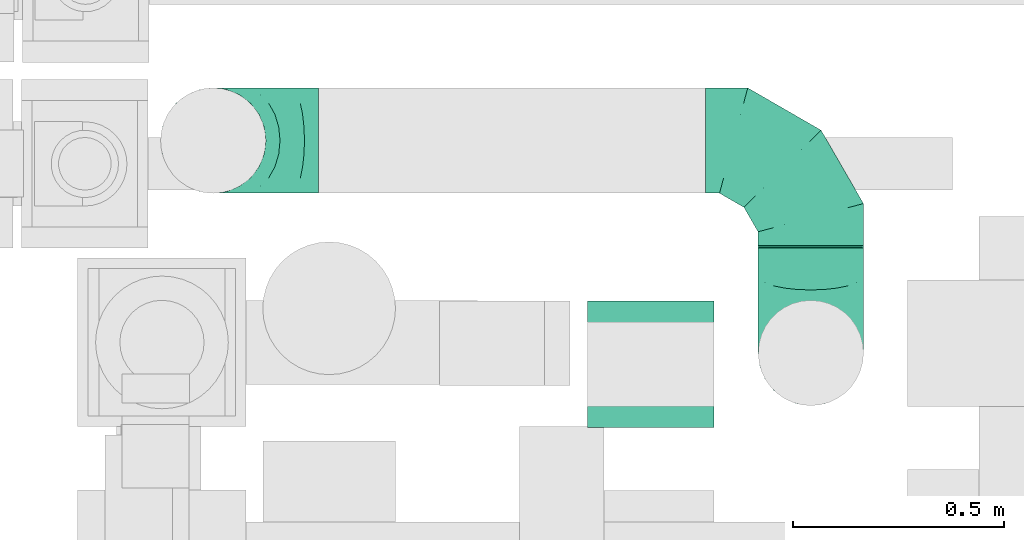
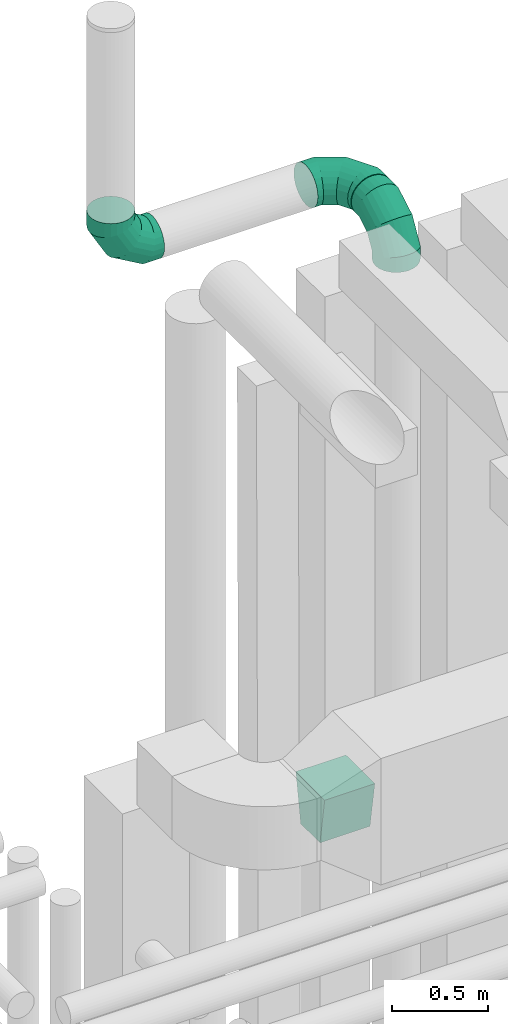
# One storey, part 98 of 337: 4 flow fittings, 1 flow segment.
"""IFC2X3 building model written with IfcOpenShell, lengths in millimetres."""

from ifc_helpers import new_model, entity, si_unit, converted_unit, derived_unit, direction, frame, origin, origin_2d_with_axis, place, context, subcontext, project, spatial, polyline, circle, outline, extrude, faceted_brep, source, transform, mapped, material, type_object, type_shapes, element, save


model = new_model("IFC2X3")

# Units and contexts
model_context = context("Model", 3, precision=0.01, world=origin(), true_north=direction((6.12303176911189e-17, 1.0)))
body_context = subcontext(model_context, "Body", "Model", "MODEL_VIEW")
ifc_project = project(units=[si_unit("LENGTHUNIT", "METRE", prefix="MILLI"), si_unit("AREAUNIT", "SQUARE_METRE"), si_unit("VOLUMEUNIT", "CUBIC_METRE"), converted_unit("PLANEANGLEUNIT", "DEGREE", entity("IfcRatioMeasure", 0.0174532925199433), si_unit("PLANEANGLEUNIT", "RADIAN"), dimensions=[0, 0, 0, 0, 0, 0, 0]), si_unit("MASSUNIT", "GRAM", prefix="KILO"), derived_unit("MASSDENSITYUNIT", [(si_unit("MASSUNIT", "GRAM", prefix="KILO"), 1), (si_unit("LENGTHUNIT", "METRE"), -3)]), derived_unit("MOMENTOFINERTIAUNIT", [(si_unit("LENGTHUNIT", "METRE"), 4)]), si_unit("TIMEUNIT", "SECOND"), si_unit("FREQUENCYUNIT", "HERTZ"), si_unit("THERMODYNAMICTEMPERATUREUNIT", "DEGREE_CELSIUS"), derived_unit("THERMALTRANSMITTANCEUNIT", [(si_unit("MASSUNIT", "GRAM", prefix="KILO"), 1), (si_unit("THERMODYNAMICTEMPERATUREUNIT", "KELVIN"), -1), (si_unit("TIMEUNIT", "SECOND"), -3)]), derived_unit("VOLUMETRICFLOWRATEUNIT", [(si_unit("LENGTHUNIT", "METRE"), 3), (si_unit("TIMEUNIT", "SECOND"), -1)]), derived_unit("MASSFLOWRATEUNIT", [(si_unit("MASSUNIT", "GRAM", prefix="KILO"), 1), (si_unit("TIMEUNIT", "SECOND"), -1)]), derived_unit("ROTATIONALFREQUENCYUNIT", [(si_unit("TIMEUNIT", "SECOND"), -1)]), si_unit("ELECTRICCURRENTUNIT", "AMPERE"), si_unit("ELECTRICVOLTAGEUNIT", "VOLT"), si_unit("POWERUNIT", "WATT"), si_unit("FORCEUNIT", "NEWTON", prefix="KILO"), si_unit("ILLUMINANCEUNIT", "LUX"), si_unit("LUMINOUSFLUXUNIT", "LUMEN"), si_unit("LUMINOUSINTENSITYUNIT", "CANDELA"), derived_unit("USERDEFINED", [(si_unit("MASSUNIT", "GRAM", prefix="KILO"), -1), (si_unit("LENGTHUNIT", "METRE"), -2), (si_unit("TIMEUNIT", "SECOND"), 3), (si_unit("LUMINOUSFLUXUNIT", "LUMEN"), 1)]), derived_unit("LINEARVELOCITYUNIT", [(si_unit("LENGTHUNIT", "METRE"), 1), (si_unit("TIMEUNIT", "SECOND"), -1)]), si_unit("PRESSUREUNIT", "PASCAL"), derived_unit("USERDEFINED", [(si_unit("LENGTHUNIT", "METRE"), -2), (si_unit("MASSUNIT", "GRAM", prefix="KILO"), 1), (si_unit("TIMEUNIT", "SECOND"), -2)]), derived_unit("LINEARFORCEUNIT", [(si_unit("MASSUNIT", "GRAM", prefix="KILO"), 1), (si_unit("LENGTHUNIT", "METRE"), 1), (si_unit("TIMEUNIT", "SECOND"), -2), (si_unit("LENGTHUNIT", "METRE"), -1)]), derived_unit("PLANARFORCEUNIT", [(si_unit("MASSUNIT", "GRAM", prefix="KILO"), 1), (si_unit("LENGTHUNIT", "METRE"), 1), (si_unit("TIMEUNIT", "SECOND"), -2), (si_unit("LENGTHUNIT", "METRE"), -2)])], contexts=[model_context])

# Site, building, storey
site_placement = place(None, origin())
site = spatial("IfcSite", under=ifc_project, at=site_placement, CompositionType="ELEMENT")
building_placement = place(site_placement, origin())
building = spatial("IfcBuilding", under=site, at=building_placement, CompositionType="ELEMENT")
storey_placement = place(building_placement, origin())
storey = spatial("IfcBuildingStorey", under=building, at=storey_placement, CompositionType="ELEMENT", Elevation=0.0)

# Flow segment
duct_segment_type = type_object("IfcDuctSegmentType", PredefinedType="NOTDEFINED")
flow_segment_placement = place(storey_placement, frame((9617.86, 14160.69, 31273.7)))
element("IfcFlowSegment", 1, at=flow_segment_placement, inside=storey, type_object=duct_segment_type, context=body_context, shape_type="SweptSolid", body=[
    extrude(circle(Radius=125.0, at=origin_2d_with_axis()), frame((126.6, 0.0, 126.6), z_axis=(0.0, 1.0, 0.0), x_axis=(1.0, 0.0, 0.0)), (0.0, 0.0, 1.0), 4.04874515178236),
])

# Flow fittings
ifc_material = material()
duct_fitting_type_1 = type_object("IfcDuctFittingType", PredefinedType="NOTDEFINED", material=ifc_material)
shared_shape_1 = source(origin(), body_context, "Body", "SweptSolid", [
    extrude(outline(polyline([(-131.52, -123.3), (172.62, -123.3), (123.3, 172.62), (-164.4, 73.98), (-131.52, -123.3)])), frame((150.0, -150.0, 0.0), z_axis=(0.0, 1.0, 0.0), x_axis=(0.986393923832159, 0.0, 0.164398987305264)), (0.0, 0.0, 1.0), 300.0),
])
type_shapes(duct_fitting_type_1, [shared_shape_1])
flow_fitting_placement = place(storey_placement, frame((9364.47, 13884.03, 27715.0), z_axis=(0.0, -1.0, 0.0), x_axis=(0.0, 0.0, 1.0)))
element("IfcFlowFitting", 2, at=flow_fitting_placement, inside=storey, type_object=duct_fitting_type_1, material=ifc_material, context=body_context, shape_type="MappedRepresentation", body=[
    mapped(shared_shape_1, transform((0.0, 0.0, 0.0), scale=1.0)),
])
duct_fitting_type_2 = type_object("IfcDuctFittingType", PredefinedType="NOTDEFINED", material=ifc_material)
shared_shape_2 = source(origin(), body_context, "Body", "Brep", [
    faceted_brep([(-250.0, 0.0, -125.0), (-250.0, -32.35, -120.74), (-250.0, -62.5, -108.25), (-250.0, -88.39, -88.39), (-250.0, -108.25, -62.5), (-250.0, -120.74, -32.35), (-250.0, -125.0, 0.0), (-250.0, -120.74, 32.35), (-250.0, -108.25, 62.5), (-250.0, -88.39, 88.39), (-250.0, -62.5, 108.25), (-250.0, -32.35, 120.74), (-250.0, 0.0, 125.0), (-250.0, 32.35, 120.74), (-250.0, 62.5, 108.25), (-250.0, 88.39, 88.39), (-250.0, 108.25, 62.5), (-250.0, 120.74, 32.35), (-250.0, 125.0, 0.0), (-250.0, 120.74, -32.35), (-250.0, 108.25, -62.5), (-250.0, 88.39, -88.39), (-250.0, 62.5, -108.25), (-250.0, 32.35, -120.74), (-191.68, 32.35, 120.74), (-199.76, 62.5, 108.25), (-183.01, 0.0, 125.0), (-206.7, 88.39, 88.39), (-215.37, 120.74, 32.35), (-216.51, 125.0, 0.0), (-212.02, 108.25, 62.5), (-212.02, 108.25, -62.5), (-206.7, 88.39, -88.39), (-215.37, 120.74, -32.35), (-191.68, 32.35, -120.74), (-183.01, 0.0, -125.0), (-199.76, 62.5, -108.25), (-174.34, -32.35, -120.74), (-166.27, -62.5, -108.25), (-159.33, -88.39, -88.39), (-154.01, -108.25, -62.5), (-150.66, -120.74, -32.35), (-149.52, -125.0, 0.0), (-150.66, -120.74, 32.35), (-154.01, -108.25, 62.5), (-159.33, -88.39, 88.39), (-166.27, -62.5, 108.25), (-174.34, -32.35, 120.74), (-90.67, 90.67, 120.74), (-112.74, 112.74, 108.25), (-66.99, 66.99, 125.0), (-131.69, 131.69, 88.39), (-146.23, 146.23, 62.5), (-155.38, 155.38, 32.35), (-158.49, 158.49, 0.0), (-155.38, 155.38, -32.35), (-146.23, 146.23, -62.5), (-131.69, 131.69, -88.39), (-90.67, 90.67, -120.74), (-66.99, 66.99, -125.0), (-112.74, 112.74, -108.25), (-43.3, 43.3, -120.74), (-21.23, 21.23, -108.25), (-2.28, 2.28, -88.39), (12.26, -12.26, -62.5), (21.4, -21.4, -32.35), (24.52, -24.52, 0.0), (21.4, -21.4, 32.35), (12.26, -12.26, 62.5), (-2.28, 2.28, 88.39), (-21.23, 21.23, 108.25), (-43.3, 43.3, 120.74), (-32.35, 191.68, 120.74), (-62.5, 199.76, 108.25), (0.0, 183.01, 125.0), (-88.39, 206.7, 88.39), (-108.25, 212.02, 62.5), (-120.74, 215.37, 32.35), (-125.0, 216.51, 0.0), (-120.74, 215.37, -32.35), (-108.25, 212.02, -62.5), (-88.39, 206.7, -88.39), (-32.35, 191.68, -120.74), (0.0, 183.01, -125.0), (-62.5, 199.76, -108.25), (32.35, 174.34, -120.74), (62.5, 166.27, -108.25), (88.39, 159.33, -88.39), (108.25, 154.01, -62.5), (120.74, 150.66, -32.35), (125.0, 149.52, 0.0), (120.74, 150.66, 32.35), (108.25, 154.01, 62.5), (88.39, 159.33, 88.39), (62.5, 166.27, 108.25), (32.35, 174.34, 120.74), (-32.35, 250.0, -120.74), (-62.5, 250.0, -108.25), (-88.39, 250.0, -88.39), (-108.25, 250.0, -62.5), (-120.74, 250.0, -32.35), (-125.0, 250.0, 0.0), (-120.74, 250.0, 32.35), (-108.25, 250.0, 62.5), (-88.39, 250.0, 88.39), (-62.5, 250.0, 108.25), (-32.35, 250.0, 120.74), (0.0, 250.0, 125.0), (32.35, 250.0, 120.74), (62.5, 250.0, 108.25), (88.39, 250.0, 88.39), (108.25, 250.0, 62.5), (120.74, 250.0, 32.35), (125.0, 250.0, 0.0), (120.74, 250.0, -32.35), (108.25, 250.0, -62.5), (88.39, 250.0, -88.39), (62.5, 250.0, -108.25), (32.35, 250.0, -120.74), (0.0, 250.0, -125.0)], [[[0, 1, 2, 3, 4, 5, 6, 7, 8, 9, 10, 11, 12, 13, 14, 15, 16, 17, 18, 19, 20, 21, 22, 23]], [[24, 25, 14, 13]], [[26, 24, 13, 12]], [[14, 25, 27, 15]], [[28, 29, 18, 17]], [[30, 28, 17, 16]], [[15, 27, 30, 16]], [[20, 31, 32, 21]], [[33, 31, 20, 19]], [[18, 29, 33, 19]], [[34, 35, 0, 23]], [[36, 34, 23, 22]], [[21, 32, 36, 22]], [[1, 0, 35, 37]], [[2, 1, 37, 38]], [[38, 39, 3, 2]], [[5, 4, 40, 41]], [[6, 5, 41, 42]], [[39, 40, 4, 3]], [[6, 42, 43, 7]], [[7, 43, 44, 8]], [[8, 44, 45, 9]], [[9, 45, 46, 10]], [[10, 46, 47, 11]], [[26, 12, 11, 47]], [[48, 49, 25, 24]], [[50, 48, 24, 26]], [[27, 25, 49, 51]], [[52, 53, 28, 30]], [[51, 52, 30, 27]], [[29, 28, 53, 54]], [[55, 56, 31, 33]], [[54, 55, 33, 29]], [[32, 31, 56, 57]], [[58, 59, 35, 34]], [[60, 58, 34, 36]], [[57, 60, 36, 32]], [[37, 35, 59, 61]], [[38, 37, 61, 62]], [[39, 38, 62, 63]], [[41, 40, 64, 65]], [[42, 41, 65, 66]], [[63, 64, 40, 39]], [[43, 42, 66, 67]], [[44, 43, 67, 68]], [[68, 69, 45, 44]], [[46, 45, 69, 70]], [[47, 46, 70, 71]], [[26, 47, 71, 50]], [[72, 73, 49, 48]], [[74, 72, 48, 50]], [[51, 49, 73, 75]], [[76, 77, 53, 52]], [[75, 76, 52, 51]], [[54, 53, 77, 78]], [[79, 80, 56, 55]], [[78, 79, 55, 54]], [[57, 56, 80, 81]], [[82, 83, 59, 58]], [[84, 82, 58, 60]], [[81, 84, 60, 57]], [[61, 59, 83, 85]], [[62, 61, 85, 86]], [[63, 62, 86, 87]], [[65, 64, 88, 89]], [[66, 65, 89, 90]], [[87, 88, 64, 63]], [[67, 66, 90, 91]], [[68, 67, 91, 92]], [[92, 93, 69, 68]], [[70, 69, 93, 94]], [[71, 70, 94, 95]], [[50, 71, 95, 74]], [[96, 97, 98, 99, 100, 101, 102, 103, 104, 105, 106, 107, 108, 109, 110, 111, 112, 113, 114, 115, 116, 117, 118, 119]], [[72, 74, 107, 106]], [[73, 72, 106, 105]], [[75, 73, 105, 104]], [[77, 76, 103, 102]], [[78, 77, 102, 101]], [[75, 104, 103, 76]], [[78, 101, 100, 79]], [[79, 100, 99, 80]], [[80, 99, 98, 81]], [[84, 97, 96, 82]], [[82, 96, 119, 83]], [[84, 81, 98, 97]], [[83, 119, 118, 85]], [[85, 118, 117, 86]], [[116, 87, 86, 117]], [[88, 115, 114, 89]], [[89, 114, 113, 90]], [[115, 88, 87, 116]], [[91, 90, 113, 112]], [[92, 91, 112, 111]], [[111, 110, 93, 92]], [[95, 94, 109, 108]], [[74, 95, 108, 107]], [[110, 109, 94, 93]]]),
])
type_shapes(duct_fitting_type_2, [shared_shape_2])
for number, where, z_axis, x_axis in (
    (3, (9744.46, 14414.74, 31400.29), (0.0, 0.0, 1.0), (0.0, 1.0, 0.0)),
    (4, (9744.46, 13910.69, 31400.29), (1.0, 0.0, 3.68191275019553e-05), (0.0, -1.0, 0.0)),
    (5, (8326.39, 14414.74, 31400.29), (0.0, 1.0, 4.57960494022705e-06), (-1.0, 0.0, 0.0)),
):
    element("IfcFlowFitting", number, at=place(storey_placement, frame(where, z_axis=z_axis, x_axis=x_axis)), inside=storey, type_object=duct_fitting_type_2, material=ifc_material, context=body_context, shape_type="MappedRepresentation", body=[
        mapped(shared_shape_2, transform((0.0, 0.0, 0.0), scale=1.0)),
    ])

save(model, "model.ifc")
